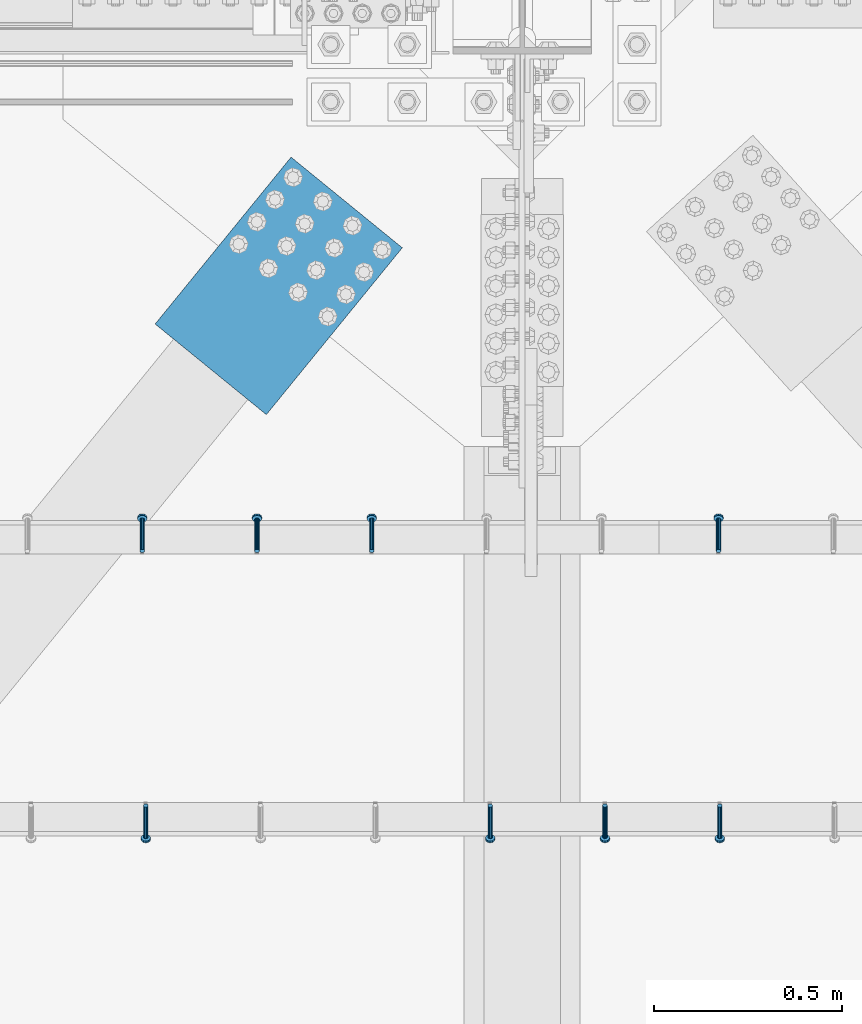
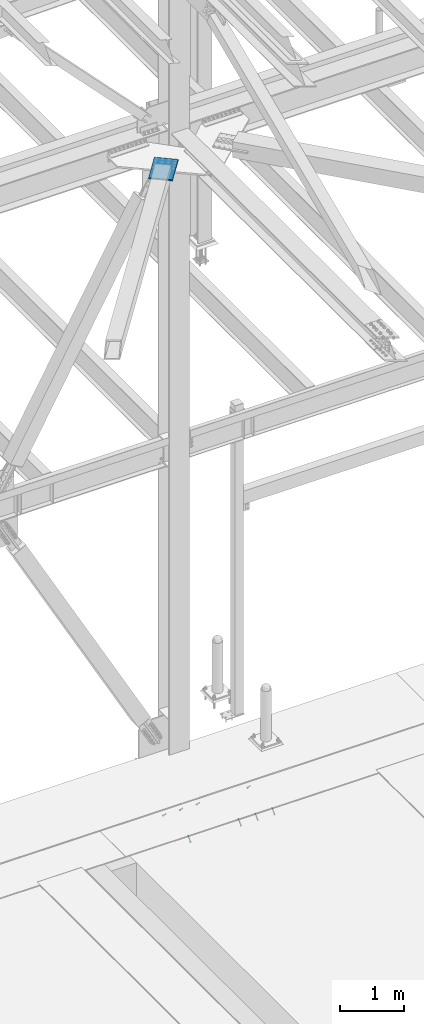
# One storey, part 2531 of 3843: 8 members, 1 beam, 4 elements without a shape of their own.
"""IFC2X3 building model written with IfcOpenShell, lengths in millimetres."""

from ifc_helpers import new_model, si_unit, frame, origin_with_axes, place, context, subcontext, project, spatial, faceted_brep, material, type_object, element, aggregate, save


model = new_model("IFC2X3")

# Units and contexts
model_context = context("Model", 3, precision=1e-05, world=origin_with_axes())
body_context = subcontext(model_context, "Body", "Model", "MODEL_VIEW")
ifc_project = project(units=[si_unit("LENGTHUNIT", "METRE", prefix="MILLI"), si_unit("AREAUNIT", "SQUARE_METRE"), si_unit("VOLUMEUNIT", "CUBIC_METRE"), si_unit("MASSUNIT", "GRAM", prefix="KILO"), si_unit("TIMEUNIT", "SECOND"), si_unit("PLANEANGLEUNIT", "RADIAN"), si_unit("SOLIDANGLEUNIT", "STERADIAN"), si_unit("THERMODYNAMICTEMPERATUREUNIT", "DEGREE_CELSIUS"), si_unit("LUMINOUSINTENSITYUNIT", "LUMEN")], contexts=[model_context])

# Site, building, storey
site_placement = place(None, origin_with_axes())
site = spatial("IfcSite", under=ifc_project, at=site_placement, CompositionType="ELEMENT")
building_placement = place(site_placement, origin_with_axes())
building = spatial("IfcBuilding", under=site, at=building_placement, Name="Undefined", CompositionType="ELEMENT")
storey_placement = place(building_placement, origin_with_axes())
storey = spatial("IfcBuildingStorey", under=building, at=storey_placement, Name="Undefined", CompositionType="ELEMENT", Elevation=0.0)

# Assembly, members
assembly_1_placement = place(storey_placement, origin_with_axes())
assembly_1 = element("IfcElementAssembly", 1, at=assembly_1_placement, inside=storey, Name="EMBED_ANGLE", AssemblyPlace="NOTDEFINED", PredefinedType="RIGID_FRAME")
ifc_material_1 = material(Name="STEEL/A108")
member_type = type_object("IfcMemberType", PredefinedType="NOTDEFINED")
member_1_placement = place(assembly_1_placement, frame((63161.050304107, 90041.2848125, 30446.6625), z_axis=(-1.0, 0.0, 0.0), x_axis=(0.0, -0.707106781186548, -0.707106781186548)))
member_1 = element("IfcMember", 2, at=member_1_placement, type_object=member_type, material=ifc_material_1, Name="HEADED STUD ANCHOR", context=body_context, shape_type="Brep", body=[
    faceted_brep([(7.27595761418343e-12, -3.18000006675175, 5.5), (0.0, -5.49999999998363, 3.1800000667572), (118.110000000976, -5.49999999999091, 3.1800000667572), (118.110000000983, -3.18000006675175, 5.5), (0.0, -6.3499999046162, 0.0), (118.110000000968, -6.34999990461256, 0.0), (0.0, -5.49999999998363, -3.1800000667572), (118.110000000976, -5.49999999999091, -3.1800000667572), (7.27595761418343e-12, -3.18000006675175, -5.5), (118.110000000983, -3.18000006675175, -5.5), (7.27595761418343e-12, -1.81898940354586e-12, -6.34999990463257), (118.110000000968, -1.81898940354586e-12, -6.34999990463257), (0.0, 3.18000006675175, -5.5), (118.110000000968, 3.18000006674811, -5.5), (7.27595761418343e-12, 5.49999999998363, -3.1800000667572), (118.110000000983, 5.49999999998363, -3.1800000667572), (7.27595761418343e-12, 6.3499999046162, 0.0), (118.110000000976, 6.34999990461256, 0.0), (7.27595761418343e-12, 5.49999999998363, 3.1800000667572), (118.110000000983, 5.49999999998363, 3.1800000667572), (0.0, 3.18000006675175, 5.5), (118.110000000968, 3.18000006674811, 5.5), (7.27595761418343e-12, -1.81898940354586e-12, 6.34999990463257), (118.110000000968, -1.81898940354586e-12, 6.34999990463257), (120.650000000991, -10.9899997710909, 6.34999990463257), (120.650000000998, -6.34000015257152, 10.9899997711182), (120.650000000991, -12.6999998092379, 0.0), (120.650000000991, -10.9899997710909, -6.34999990463257), (120.650000000998, -6.34000015257152, -10.9899997711182), (120.650000000991, -1.81898940354586e-12, -12.6899995803833), (120.650000000991, 6.34000015257152, -10.9899997711182), (120.650000000998, 10.9899997710909, -6.34999990463257), (120.650000000991, 12.6999998092342, 0.0), (120.650000000998, 10.9899997710909, 6.34999990463257), (120.650000000991, 6.34000015257152, 10.9899997711182), (120.650000000991, -1.81898940354586e-12, 12.6899995803833), (127.000000001048, -10.9899997710945, 6.34999990463257), (127.000000001048, -6.34000015257152, 10.9899997711182), (127.000000001048, -12.6999998092342, 0.0), (127.000000001048, -10.9899997710945, -6.34999990463257), (127.000000001048, -6.34000015257152, -10.9899997711182), (127.000000001048, 1.81898940354586e-12, -12.6899995803833), (127.000000001048, 6.34000015256788, -10.9899997711182), (127.000000001048, 10.9899997710909, -6.34999990463257), (127.000000001048, 12.6999998092379, 0.0), (127.000000001048, 10.9899997710909, 6.34999990463257), (127.000000001048, 6.34000015256788, 10.9899997711182), (127.000000001048, 1.81898940354586e-12, 12.6899995803833)], [[[0, 1, 2, 3]], [[1, 4, 5, 2]], [[4, 6, 7, 5]], [[6, 8, 9, 7]], [[8, 10, 11, 9]], [[10, 12, 13, 11]], [[12, 14, 15, 13]], [[14, 16, 17, 15]], [[16, 18, 19, 17]], [[18, 20, 21, 19]], [[20, 22, 23, 21]], [[22, 0, 3, 23]], [[22, 20, 18, 16, 14, 12, 10, 8, 6, 4, 1, 0]], [[3, 2, 24, 25]], [[2, 5, 26, 24]], [[5, 7, 27, 26]], [[7, 9, 28, 27]], [[9, 11, 29, 28]], [[11, 13, 30, 29]], [[13, 15, 31, 30]], [[15, 17, 32, 31]], [[17, 19, 33, 32]], [[19, 21, 34, 33]], [[21, 23, 35, 34]], [[23, 3, 25, 35]], [[25, 24, 36, 37]], [[24, 26, 38, 36]], [[26, 27, 39, 38]], [[27, 28, 40, 39]], [[28, 29, 41, 40]], [[29, 30, 42, 41]], [[30, 31, 43, 42]], [[31, 32, 44, 43]], [[32, 33, 45, 44]], [[33, 34, 46, 45]], [[34, 35, 47, 46]], [[35, 25, 37, 47]], [[38, 39, 40, 41, 42, 43, 44, 45, 46, 47, 37, 36]]]),
])
member_2_placement = place(assembly_1_placement, frame((62856.250304107, 90041.2848125, 30446.6625), z_axis=(-1.0, 0.0, 0.0), x_axis=(0.0, -0.707106781186548, -0.707106781186548)))
member_2 = element("IfcMember", 3, at=member_2_placement, type_object=member_type, material=ifc_material_1, Name="HEADED STUD ANCHOR", context=body_context, shape_type="Brep", body=[
    faceted_brep([(7.27595761418343e-12, -3.18000006675175, 5.5), (0.0, -5.49999999998363, 3.1800000667572), (118.110000000976, -5.49999999999091, 3.1800000667572), (118.110000000983, -3.18000006675175, 5.5), (0.0, -6.3499999046162, 0.0), (118.110000000968, -6.34999990461256, 0.0), (0.0, -5.49999999998363, -3.1800000667572), (118.110000000976, -5.49999999999091, -3.1800000667572), (7.27595761418343e-12, -3.18000006675175, -5.5), (118.110000000983, -3.18000006675175, -5.5), (7.27595761418343e-12, -1.81898940354586e-12, -6.34999990463257), (118.110000000968, -1.81898940354586e-12, -6.34999990463257), (0.0, 3.18000006675175, -5.5), (118.110000000968, 3.18000006674811, -5.5), (7.27595761418343e-12, 5.49999999998363, -3.1800000667572), (118.110000000983, 5.49999999998363, -3.1800000667572), (7.27595761418343e-12, 6.3499999046162, 0.0), (118.110000000976, 6.34999990461256, 0.0), (7.27595761418343e-12, 5.49999999998363, 3.1800000667572), (118.110000000983, 5.49999999998363, 3.1800000667572), (0.0, 3.18000006675175, 5.5), (118.110000000968, 3.18000006674811, 5.5), (7.27595761418343e-12, -1.81898940354586e-12, 6.34999990463257), (118.110000000968, -1.81898940354586e-12, 6.34999990463257), (120.650000000991, -10.9899997710909, 6.34999990463257), (120.650000000998, -6.34000015257152, 10.9899997711182), (120.650000000991, -12.6999998092379, 0.0), (120.650000000991, -10.9899997710909, -6.34999990463257), (120.650000000998, -6.34000015257152, -10.9899997711182), (120.650000000991, -1.81898940354586e-12, -12.6899995803833), (120.650000000991, 6.34000015257152, -10.9899997711182), (120.650000000998, 10.9899997710909, -6.34999990463257), (120.650000000991, 12.6999998092342, 0.0), (120.650000000998, 10.9899997710909, 6.34999990463257), (120.650000000991, 6.34000015257152, 10.9899997711182), (120.650000000991, -1.81898940354586e-12, 12.6899995803833), (127.000000001048, -10.9899997710945, 6.34999990463257), (127.000000001048, -6.34000015257152, 10.9899997711182), (127.000000001048, -12.6999998092342, 0.0), (127.000000001048, -10.9899997710945, -6.34999990463257), (127.000000001048, -6.34000015257152, -10.9899997711182), (127.000000001048, 1.81898940354586e-12, -12.6899995803833), (127.000000001048, 6.34000015256788, -10.9899997711182), (127.000000001048, 10.9899997710909, -6.34999990463257), (127.000000001048, 12.6999998092379, 0.0), (127.000000001048, 10.9899997710909, 6.34999990463257), (127.000000001048, 6.34000015256788, 10.9899997711182), (127.000000001048, 1.81898940354586e-12, 12.6899995803833)], [[[0, 1, 2, 3]], [[1, 4, 5, 2]], [[4, 6, 7, 5]], [[6, 8, 9, 7]], [[8, 10, 11, 9]], [[10, 12, 13, 11]], [[12, 14, 15, 13]], [[14, 16, 17, 15]], [[16, 18, 19, 17]], [[18, 20, 21, 19]], [[20, 22, 23, 21]], [[22, 0, 3, 23]], [[22, 20, 18, 16, 14, 12, 10, 8, 6, 4, 1, 0]], [[3, 2, 24, 25]], [[2, 5, 26, 24]], [[5, 7, 27, 26]], [[7, 9, 28, 27]], [[9, 11, 29, 28]], [[11, 13, 30, 29]], [[13, 15, 31, 30]], [[15, 17, 32, 31]], [[17, 19, 33, 32]], [[19, 21, 34, 33]], [[21, 23, 35, 34]], [[23, 3, 25, 35]], [[25, 24, 36, 37]], [[24, 26, 38, 36]], [[26, 27, 39, 38]], [[27, 28, 40, 39]], [[28, 29, 41, 40]], [[29, 30, 42, 41]], [[30, 31, 43, 42]], [[31, 32, 44, 43]], [[32, 33, 45, 44]], [[33, 34, 46, 45]], [[34, 35, 47, 46]], [[35, 25, 37, 47]], [[38, 39, 40, 41, 42, 43, 44, 45, 46, 47, 37, 36]]]),
])
member_3_placement = place(assembly_1_placement, frame((62551.450304107, 90041.2848125, 30446.6625), z_axis=(-1.0, 0.0, 0.0), x_axis=(0.0, -0.707106781186548, -0.707106781186548)))
member_3 = element("IfcMember", 4, at=member_3_placement, type_object=member_type, material=ifc_material_1, Name="HEADED STUD ANCHOR", context=body_context, shape_type="Brep", body=[
    faceted_brep([(7.27595761418343e-12, -3.18000006675175, 5.5), (0.0, -5.49999999998363, 3.1800000667572), (118.110000000976, -5.49999999999091, 3.1800000667572), (118.110000000983, -3.18000006675175, 5.5), (0.0, -6.3499999046162, 0.0), (118.110000000968, -6.34999990461256, 0.0), (0.0, -5.49999999998363, -3.1800000667572), (118.110000000976, -5.49999999999091, -3.1800000667572), (7.27595761418343e-12, -3.18000006675175, -5.5), (118.110000000983, -3.18000006675175, -5.5), (7.27595761418343e-12, -1.81898940354586e-12, -6.34999990463257), (118.110000000968, -1.81898940354586e-12, -6.34999990463257), (0.0, 3.18000006675175, -5.5), (118.110000000968, 3.18000006674811, -5.5), (7.27595761418343e-12, 5.49999999998363, -3.1800000667572), (118.110000000983, 5.49999999998363, -3.1800000667572), (7.27595761418343e-12, 6.3499999046162, 0.0), (118.110000000976, 6.34999990461256, 0.0), (7.27595761418343e-12, 5.49999999998363, 3.1800000667572), (118.110000000983, 5.49999999998363, 3.1800000667572), (0.0, 3.18000006675175, 5.5), (118.110000000968, 3.18000006674811, 5.5), (7.27595761418343e-12, -1.81898940354586e-12, 6.34999990463257), (118.110000000968, -1.81898940354586e-12, 6.34999990463257), (120.650000000991, -10.9899997710909, 6.34999990463257), (120.650000000998, -6.34000015257152, 10.9899997711182), (120.650000000991, -12.6999998092379, 0.0), (120.650000000991, -10.9899997710909, -6.34999990463257), (120.650000000998, -6.34000015257152, -10.9899997711182), (120.650000000991, -1.81898940354586e-12, -12.6899995803833), (120.650000000991, 6.34000015257152, -10.9899997711182), (120.650000000998, 10.9899997710909, -6.34999990463257), (120.650000000991, 12.6999998092342, 0.0), (120.650000000998, 10.9899997710909, 6.34999990463257), (120.650000000991, 6.34000015257152, 10.9899997711182), (120.650000000991, -1.81898940354586e-12, 12.6899995803833), (127.000000001048, -10.9899997710945, 6.34999990463257), (127.000000001048, -6.34000015257152, 10.9899997711182), (127.000000001048, -12.6999998092342, 0.0), (127.000000001048, -10.9899997710945, -6.34999990463257), (127.000000001048, -6.34000015257152, -10.9899997711182), (127.000000001048, 1.81898940354586e-12, -12.6899995803833), (127.000000001048, 6.34000015256788, -10.9899997711182), (127.000000001048, 10.9899997710909, -6.34999990463257), (127.000000001048, 12.6999998092379, 0.0), (127.000000001048, 10.9899997710909, 6.34999990463257), (127.000000001048, 6.34000015256788, 10.9899997711182), (127.000000001048, 1.81898940354586e-12, 12.6899995803833)], [[[0, 1, 2, 3]], [[1, 4, 5, 2]], [[4, 6, 7, 5]], [[6, 8, 9, 7]], [[8, 10, 11, 9]], [[10, 12, 13, 11]], [[12, 14, 15, 13]], [[14, 16, 17, 15]], [[16, 18, 19, 17]], [[18, 20, 21, 19]], [[20, 22, 23, 21]], [[22, 0, 3, 23]], [[22, 20, 18, 16, 14, 12, 10, 8, 6, 4, 1, 0]], [[3, 2, 24, 25]], [[2, 5, 26, 24]], [[5, 7, 27, 26]], [[7, 9, 28, 27]], [[9, 11, 29, 28]], [[11, 13, 30, 29]], [[13, 15, 31, 30]], [[15, 17, 32, 31]], [[17, 19, 33, 32]], [[19, 21, 34, 33]], [[21, 23, 35, 34]], [[23, 3, 25, 35]], [[25, 24, 36, 37]], [[24, 26, 38, 36]], [[26, 27, 39, 38]], [[27, 28, 40, 39]], [[28, 29, 41, 40]], [[29, 30, 42, 41]], [[30, 31, 43, 42]], [[31, 32, 44, 43]], [[32, 33, 45, 44]], [[33, 34, 46, 45]], [[34, 35, 47, 46]], [[35, 25, 37, 47]], [[38, 39, 40, 41, 42, 43, 44, 45, 46, 47, 37, 36]]]),
])
member_4_placement = place(assembly_1_placement, frame((61637.050304107, 90041.2848125, 30446.6625), z_axis=(-1.0, 0.0, 0.0), x_axis=(0.0, -0.707106781186548, -0.707106781186548)))
member_4 = element("IfcMember", 5, at=member_4_placement, type_object=member_type, material=ifc_material_1, Name="HEADED STUD ANCHOR", context=body_context, shape_type="Brep", body=[
    faceted_brep([(7.27595761418343e-12, -3.18000006675175, 5.5), (0.0, -5.49999999998363, 3.1800000667572), (118.110000000976, -5.49999999999091, 3.1800000667572), (118.110000000983, -3.18000006675175, 5.5), (0.0, -6.3499999046162, 0.0), (118.110000000968, -6.34999990461256, 0.0), (0.0, -5.49999999998363, -3.1800000667572), (118.110000000976, -5.49999999999091, -3.1800000667572), (7.27595761418343e-12, -3.18000006675175, -5.5), (118.110000000983, -3.18000006675175, -5.5), (7.27595761418343e-12, -1.81898940354586e-12, -6.34999990463257), (118.110000000968, -1.81898940354586e-12, -6.34999990463257), (0.0, 3.18000006675175, -5.5), (118.110000000968, 3.18000006674811, -5.5), (7.27595761418343e-12, 5.49999999998363, -3.1800000667572), (118.110000000983, 5.49999999998363, -3.1800000667572), (7.27595761418343e-12, 6.3499999046162, 0.0), (118.110000000976, 6.34999990461256, 0.0), (7.27595761418343e-12, 5.49999999998363, 3.1800000667572), (118.110000000983, 5.49999999998363, 3.1800000667572), (0.0, 3.18000006675175, 5.5), (118.110000000968, 3.18000006674811, 5.5), (7.27595761418343e-12, -1.81898940354586e-12, 6.34999990463257), (118.110000000968, -1.81898940354586e-12, 6.34999990463257), (120.650000000991, -10.9899997710909, 6.34999990463257), (120.650000000998, -6.34000015257152, 10.9899997711182), (120.650000000991, -12.6999998092379, 0.0), (120.650000000991, -10.9899997710909, -6.34999990463257), (120.650000000998, -6.34000015257152, -10.9899997711182), (120.650000000991, -1.81898940354586e-12, -12.6899995803833), (120.650000000991, 6.34000015257152, -10.9899997711182), (120.650000000998, 10.9899997710909, -6.34999990463257), (120.650000000991, 12.6999998092342, 0.0), (120.650000000998, 10.9899997710909, 6.34999990463257), (120.650000000991, 6.34000015257152, 10.9899997711182), (120.650000000991, -1.81898940354586e-12, 12.6899995803833), (127.000000001048, -10.9899997710945, 6.34999990463257), (127.000000001048, -6.34000015257152, 10.9899997711182), (127.000000001048, -12.6999998092342, 0.0), (127.000000001048, -10.9899997710945, -6.34999990463257), (127.000000001048, -6.34000015257152, -10.9899997711182), (127.000000001048, 1.81898940354586e-12, -12.6899995803833), (127.000000001048, 6.34000015256788, -10.9899997711182), (127.000000001048, 10.9899997710909, -6.34999990463257), (127.000000001048, 12.6999998092379, 0.0), (127.000000001048, 10.9899997710909, 6.34999990463257), (127.000000001048, 6.34000015256788, 10.9899997711182), (127.000000001048, 1.81898940354586e-12, 12.6899995803833)], [[[0, 1, 2, 3]], [[1, 4, 5, 2]], [[4, 6, 7, 5]], [[6, 8, 9, 7]], [[8, 10, 11, 9]], [[10, 12, 13, 11]], [[12, 14, 15, 13]], [[14, 16, 17, 15]], [[16, 18, 19, 17]], [[18, 20, 21, 19]], [[20, 22, 23, 21]], [[22, 0, 3, 23]], [[22, 20, 18, 16, 14, 12, 10, 8, 6, 4, 1, 0]], [[3, 2, 24, 25]], [[2, 5, 26, 24]], [[5, 7, 27, 26]], [[7, 9, 28, 27]], [[9, 11, 29, 28]], [[11, 13, 30, 29]], [[13, 15, 31, 30]], [[15, 17, 32, 31]], [[17, 19, 33, 32]], [[19, 21, 34, 33]], [[21, 23, 35, 34]], [[23, 3, 25, 35]], [[25, 24, 36, 37]], [[24, 26, 38, 36]], [[26, 27, 39, 38]], [[27, 28, 40, 39]], [[28, 29, 41, 40]], [[29, 30, 42, 41]], [[30, 31, 43, 42]], [[31, 32, 44, 43]], [[32, 33, 45, 44]], [[33, 34, 46, 45]], [[34, 35, 47, 46]], [[35, 25, 37, 47]], [[38, 39, 40, 41, 42, 43, 44, 45, 46, 47, 37, 36]]]),
])
aggregate(assembly_1, [member_1, member_2, member_3, member_4])

# Assembly, member
assembly_2_placement = place(storey_placement, origin_with_axes())
assembly_2 = element("IfcElementAssembly", 6, at=assembly_2_placement, inside=storey, Name="EMBED_ANGLE", AssemblyPlace="NOTDEFINED", PredefinedType="RIGID_FRAME")
member_5_placement = place(assembly_2_placement, frame((63157.8621552734, 90717.5605224609, 30446.6625), z_axis=(-1.0, 0.0, 0.0), x_axis=(5.70000238222118e-08, 0.707106781186546, -0.707106781186546)))
member_5 = element("IfcMember", 7, at=member_5_placement, type_object=member_type, material=ifc_material_1, Name="HEADED STUD ANCHOR", context=body_context, shape_type="Brep", body=[
    faceted_brep([(7.27595761418343e-12, -3.18000006675175, 5.5), (0.0, -5.49999999998363, 3.1800000667572), (118.110000000976, -5.49999999999091, 3.1800000667572), (118.110000000983, -3.18000006675175, 5.5), (0.0, -6.3499999046162, 0.0), (118.110000000968, -6.34999990461256, 0.0), (0.0, -5.49999999998363, -3.1800000667572), (118.110000000976, -5.49999999999091, -3.1800000667572), (7.27595761418343e-12, -3.18000006675175, -5.5), (118.110000000983, -3.18000006675175, -5.5), (7.27595761418343e-12, -1.81898940354586e-12, -6.34999990463257), (118.110000000968, -1.81898940354586e-12, -6.34999990463257), (0.0, 3.18000006675175, -5.5), (118.110000000968, 3.18000006674811, -5.5), (7.27595761418343e-12, 5.49999999998363, -3.1800000667572), (118.110000000983, 5.49999999998363, -3.1800000667572), (7.27595761418343e-12, 6.3499999046162, 0.0), (118.110000000976, 6.34999990461256, 0.0), (7.27595761418343e-12, 5.49999999998363, 3.1800000667572), (118.110000000983, 5.49999999998363, 3.1800000667572), (0.0, 3.18000006675175, 5.5), (118.110000000968, 3.18000006674811, 5.5), (7.27595761418343e-12, -1.81898940354586e-12, 6.34999990463257), (118.110000000968, -1.81898940354586e-12, 6.34999990463257), (120.650000000991, -10.9899997710909, 6.34999990463257), (120.650000000998, -6.34000015257152, 10.9899997711182), (120.650000000991, -12.6999998092379, 0.0), (120.650000000991, -10.9899997710909, -6.34999990463257), (120.650000000998, -6.34000015257152, -10.9899997711182), (120.650000000991, -1.81898940354586e-12, -12.6899995803833), (120.650000000991, 6.34000015257152, -10.9899997711182), (120.650000000998, 10.9899997710909, -6.34999990463257), (120.650000000991, 12.6999998092342, 0.0), (120.650000000998, 10.9899997710909, 6.34999990463257), (120.650000000991, 6.34000015257152, 10.9899997711182), (120.650000000991, -1.81898940354586e-12, 12.6899995803833), (127.000000001048, -10.9899997710945, 6.34999990463257), (127.000000001048, -6.34000015257152, 10.9899997711182), (127.000000001048, -12.6999998092342, 0.0), (127.000000001048, -10.9899997710945, -6.34999990463257), (127.000000001048, -6.34000015257152, -10.9899997711182), (127.000000001048, 1.81898940354586e-12, -12.6899995803833), (127.000000001048, 6.34000015256788, -10.9899997711182), (127.000000001048, 10.9899997710909, -6.34999990463257), (127.000000001048, 12.6999998092379, 0.0), (127.000000001048, 10.9899997710909, 6.34999990463257), (127.000000001048, 6.34000015256788, 10.9899997711182), (127.000000001048, 1.81898940354586e-12, 12.6899995803833)], [[[0, 1, 2, 3]], [[1, 4, 5, 2]], [[4, 6, 7, 5]], [[6, 8, 9, 7]], [[8, 10, 11, 9]], [[10, 12, 13, 11]], [[12, 14, 15, 13]], [[14, 16, 17, 15]], [[16, 18, 19, 17]], [[18, 20, 21, 19]], [[20, 22, 23, 21]], [[22, 0, 3, 23]], [[22, 20, 18, 16, 14, 12, 10, 8, 6, 4, 1, 0]], [[3, 2, 24, 25]], [[2, 5, 26, 24]], [[5, 7, 27, 26]], [[7, 9, 28, 27]], [[9, 11, 29, 28]], [[11, 13, 30, 29]], [[13, 15, 31, 30]], [[15, 17, 32, 31]], [[17, 19, 33, 32]], [[19, 21, 34, 33]], [[21, 23, 35, 34]], [[23, 3, 25, 35]], [[25, 24, 36, 37]], [[24, 26, 38, 36]], [[26, 27, 39, 38]], [[27, 28, 40, 39]], [[28, 29, 41, 40]], [[29, 30, 42, 41]], [[30, 31, 43, 42]], [[31, 32, 44, 43]], [[32, 33, 45, 44]], [[33, 34, 46, 45]], [[34, 35, 47, 46]], [[35, 25, 37, 47]], [[38, 39, 40, 41, 42, 43, 44, 45, 46, 47, 37, 36]]]),
])
aggregate(assembly_2, [member_5])

# Assembly, members
assembly_3_placement = place(storey_placement, origin_with_axes())
assembly_3 = element("IfcElementAssembly", 8, at=assembly_3_placement, inside=storey, Name="EMBED_ANGLE", AssemblyPlace="NOTDEFINED", PredefinedType="RIGID_FRAME")
member_6_placement = place(assembly_3_placement, frame((62237.1121552734, 90717.5605224609, 30446.6625), z_axis=(-1.0, 0.0, 0.0), x_axis=(5.70000238222118e-08, 0.707106781186546, -0.707106781186546)))
member_6 = element("IfcMember", 9, at=member_6_placement, type_object=member_type, material=ifc_material_1, Name="HEADED STUD ANCHOR", context=body_context, shape_type="Brep", body=[
    faceted_brep([(7.27595761418343e-12, -3.18000006675175, 5.5), (0.0, -5.49999999998363, 3.1800000667572), (118.110000000976, -5.49999999999091, 3.1800000667572), (118.110000000983, -3.18000006675175, 5.5), (0.0, -6.3499999046162, 0.0), (118.110000000968, -6.34999990461256, 0.0), (0.0, -5.49999999998363, -3.1800000667572), (118.110000000976, -5.49999999999091, -3.1800000667572), (7.27595761418343e-12, -3.18000006675175, -5.5), (118.110000000983, -3.18000006675175, -5.5), (7.27595761418343e-12, -1.81898940354586e-12, -6.34999990463257), (118.110000000968, -1.81898940354586e-12, -6.34999990463257), (0.0, 3.18000006675175, -5.5), (118.110000000968, 3.18000006674811, -5.5), (7.27595761418343e-12, 5.49999999998363, -3.1800000667572), (118.110000000983, 5.49999999998363, -3.1800000667572), (7.27595761418343e-12, 6.3499999046162, 0.0), (118.110000000976, 6.34999990461256, 0.0), (7.27595761418343e-12, 5.49999999998363, 3.1800000667572), (118.110000000983, 5.49999999998363, 3.1800000667572), (0.0, 3.18000006675175, 5.5), (118.110000000968, 3.18000006674811, 5.5), (7.27595761418343e-12, -1.81898940354586e-12, 6.34999990463257), (118.110000000968, -1.81898940354586e-12, 6.34999990463257), (120.650000000991, -10.9899997710909, 6.34999990463257), (120.650000000998, -6.34000015257152, 10.9899997711182), (120.650000000991, -12.6999998092379, 0.0), (120.650000000991, -10.9899997710909, -6.34999990463257), (120.650000000998, -6.34000015257152, -10.9899997711182), (120.650000000991, -1.81898940354586e-12, -12.6899995803833), (120.650000000991, 6.34000015257152, -10.9899997711182), (120.650000000998, 10.9899997710909, -6.34999990463257), (120.650000000991, 12.6999998092342, 0.0), (120.650000000998, 10.9899997710909, 6.34999990463257), (120.650000000991, 6.34000015257152, 10.9899997711182), (120.650000000991, -1.81898940354586e-12, 12.6899995803833), (127.000000001048, -10.9899997710945, 6.34999990463257), (127.000000001048, -6.34000015257152, 10.9899997711182), (127.000000001048, -12.6999998092342, 0.0), (127.000000001048, -10.9899997710945, -6.34999990463257), (127.000000001048, -6.34000015257152, -10.9899997711182), (127.000000001048, 1.81898940354586e-12, -12.6899995803833), (127.000000001048, 6.34000015256788, -10.9899997711182), (127.000000001048, 10.9899997710909, -6.34999990463257), (127.000000001048, 12.6999998092379, 0.0), (127.000000001048, 10.9899997710909, 6.34999990463257), (127.000000001048, 6.34000015256788, 10.9899997711182), (127.000000001048, 1.81898940354586e-12, 12.6899995803833)], [[[0, 1, 2, 3]], [[1, 4, 5, 2]], [[4, 6, 7, 5]], [[6, 8, 9, 7]], [[8, 10, 11, 9]], [[10, 12, 13, 11]], [[12, 14, 15, 13]], [[14, 16, 17, 15]], [[16, 18, 19, 17]], [[18, 20, 21, 19]], [[20, 22, 23, 21]], [[22, 0, 3, 23]], [[22, 20, 18, 16, 14, 12, 10, 8, 6, 4, 1, 0]], [[3, 2, 24, 25]], [[2, 5, 26, 24]], [[5, 7, 27, 26]], [[7, 9, 28, 27]], [[9, 11, 29, 28]], [[11, 13, 30, 29]], [[13, 15, 31, 30]], [[15, 17, 32, 31]], [[17, 19, 33, 32]], [[19, 21, 34, 33]], [[21, 23, 35, 34]], [[23, 3, 25, 35]], [[25, 24, 36, 37]], [[24, 26, 38, 36]], [[26, 27, 39, 38]], [[27, 28, 40, 39]], [[28, 29, 41, 40]], [[29, 30, 42, 41]], [[30, 31, 43, 42]], [[31, 32, 44, 43]], [[32, 33, 45, 44]], [[33, 34, 46, 45]], [[34, 35, 47, 46]], [[35, 25, 37, 47]], [[38, 39, 40, 41, 42, 43, 44, 45, 46, 47, 37, 36]]]),
])
member_7_placement = place(assembly_3_placement, frame((61932.3121552734, 90717.5605224609, 30446.6625), z_axis=(-1.0, 0.0, 0.0), x_axis=(5.70000238222118e-08, 0.707106781186546, -0.707106781186546)))
member_7 = element("IfcMember", 10, at=member_7_placement, type_object=member_type, material=ifc_material_1, Name="HEADED STUD ANCHOR", context=body_context, shape_type="Brep", body=[
    faceted_brep([(7.27595761418343e-12, -3.18000006675175, 5.5), (0.0, -5.49999999998363, 3.1800000667572), (118.110000000976, -5.49999999999091, 3.1800000667572), (118.110000000983, -3.18000006675175, 5.5), (0.0, -6.3499999046162, 0.0), (118.110000000968, -6.34999990461256, 0.0), (0.0, -5.49999999998363, -3.1800000667572), (118.110000000976, -5.49999999999091, -3.1800000667572), (7.27595761418343e-12, -3.18000006675175, -5.5), (118.110000000983, -3.18000006675175, -5.5), (7.27595761418343e-12, -1.81898940354586e-12, -6.34999990463257), (118.110000000968, -1.81898940354586e-12, -6.34999990463257), (0.0, 3.18000006675175, -5.5), (118.110000000968, 3.18000006674811, -5.5), (7.27595761418343e-12, 5.49999999998363, -3.1800000667572), (118.110000000983, 5.49999999998363, -3.1800000667572), (7.27595761418343e-12, 6.3499999046162, 0.0), (118.110000000976, 6.34999990461256, 0.0), (7.27595761418343e-12, 5.49999999998363, 3.1800000667572), (118.110000000983, 5.49999999998363, 3.1800000667572), (0.0, 3.18000006675175, 5.5), (118.110000000968, 3.18000006674811, 5.5), (7.27595761418343e-12, -1.81898940354586e-12, 6.34999990463257), (118.110000000968, -1.81898940354586e-12, 6.34999990463257), (120.650000000991, -10.9899997710909, 6.34999990463257), (120.650000000998, -6.34000015257152, 10.9899997711182), (120.650000000991, -12.6999998092379, 0.0), (120.650000000991, -10.9899997710909, -6.34999990463257), (120.650000000998, -6.34000015257152, -10.9899997711182), (120.650000000991, -1.81898940354586e-12, -12.6899995803833), (120.650000000991, 6.34000015257152, -10.9899997711182), (120.650000000998, 10.9899997710909, -6.34999990463257), (120.650000000991, 12.6999998092342, 0.0), (120.650000000998, 10.9899997710909, 6.34999990463257), (120.650000000991, 6.34000015257152, 10.9899997711182), (120.650000000991, -1.81898940354586e-12, 12.6899995803833), (127.000000001048, -10.9899997710945, 6.34999990463257), (127.000000001048, -6.34000015257152, 10.9899997711182), (127.000000001048, -12.6999998092342, 0.0), (127.000000001048, -10.9899997710945, -6.34999990463257), (127.000000001048, -6.34000015257152, -10.9899997711182), (127.000000001048, 1.81898940354586e-12, -12.6899995803833), (127.000000001048, 6.34000015256788, -10.9899997711182), (127.000000001048, 10.9899997710909, -6.34999990463257), (127.000000001048, 12.6999998092379, 0.0), (127.000000001048, 10.9899997710909, 6.34999990463257), (127.000000001048, 6.34000015256788, 10.9899997711182), (127.000000001048, 1.81898940354586e-12, 12.6899995803833)], [[[0, 1, 2, 3]], [[1, 4, 5, 2]], [[4, 6, 7, 5]], [[6, 8, 9, 7]], [[8, 10, 11, 9]], [[10, 12, 13, 11]], [[12, 14, 15, 13]], [[14, 16, 17, 15]], [[16, 18, 19, 17]], [[18, 20, 21, 19]], [[20, 22, 23, 21]], [[22, 0, 3, 23]], [[22, 20, 18, 16, 14, 12, 10, 8, 6, 4, 1, 0]], [[3, 2, 24, 25]], [[2, 5, 26, 24]], [[5, 7, 27, 26]], [[7, 9, 28, 27]], [[9, 11, 29, 28]], [[11, 13, 30, 29]], [[13, 15, 31, 30]], [[15, 17, 32, 31]], [[17, 19, 33, 32]], [[19, 21, 34, 33]], [[21, 23, 35, 34]], [[23, 3, 25, 35]], [[25, 24, 36, 37]], [[24, 26, 38, 36]], [[26, 27, 39, 38]], [[27, 28, 40, 39]], [[28, 29, 41, 40]], [[29, 30, 42, 41]], [[30, 31, 43, 42]], [[31, 32, 44, 43]], [[32, 33, 45, 44]], [[33, 34, 46, 45]], [[34, 35, 47, 46]], [[35, 25, 37, 47]], [[38, 39, 40, 41, 42, 43, 44, 45, 46, 47, 37, 36]]]),
])
member_8_placement = place(assembly_3_placement, frame((61627.5121552734, 90717.5605224609, 30446.6625), z_axis=(-1.0, 0.0, 0.0), x_axis=(5.70000238222118e-08, 0.707106781186546, -0.707106781186546)))
member_8 = element("IfcMember", 11, at=member_8_placement, type_object=member_type, material=ifc_material_1, Name="HEADED STUD ANCHOR", context=body_context, shape_type="Brep", body=[
    faceted_brep([(7.27595761418343e-12, -3.18000006675175, 5.5), (0.0, -5.49999999998363, 3.1800000667572), (118.110000000976, -5.49999999999091, 3.1800000667572), (118.110000000983, -3.18000006675175, 5.5), (0.0, -6.3499999046162, 0.0), (118.110000000968, -6.34999990461256, 0.0), (0.0, -5.49999999998363, -3.1800000667572), (118.110000000976, -5.49999999999091, -3.1800000667572), (7.27595761418343e-12, -3.18000006675175, -5.5), (118.110000000983, -3.18000006675175, -5.5), (7.27595761418343e-12, -1.81898940354586e-12, -6.34999990463257), (118.110000000968, -1.81898940354586e-12, -6.34999990463257), (0.0, 3.18000006675175, -5.5), (118.110000000968, 3.18000006674811, -5.5), (7.27595761418343e-12, 5.49999999998363, -3.1800000667572), (118.110000000983, 5.49999999998363, -3.1800000667572), (7.27595761418343e-12, 6.3499999046162, 0.0), (118.110000000976, 6.34999990461256, 0.0), (7.27595761418343e-12, 5.49999999998363, 3.1800000667572), (118.110000000983, 5.49999999998363, 3.1800000667572), (0.0, 3.18000006675175, 5.5), (118.110000000968, 3.18000006674811, 5.5), (7.27595761418343e-12, -1.81898940354586e-12, 6.34999990463257), (118.110000000968, -1.81898940354586e-12, 6.34999990463257), (120.650000000991, -10.9899997710909, 6.34999990463257), (120.650000000998, -6.34000015257152, 10.9899997711182), (120.650000000991, -12.6999998092379, 0.0), (120.650000000991, -10.9899997710909, -6.34999990463257), (120.650000000998, -6.34000015257152, -10.9899997711182), (120.650000000991, -1.81898940354586e-12, -12.6899995803833), (120.650000000991, 6.34000015257152, -10.9899997711182), (120.650000000998, 10.9899997710909, -6.34999990463257), (120.650000000991, 12.6999998092342, 0.0), (120.650000000998, 10.9899997710909, 6.34999990463257), (120.650000000991, 6.34000015257152, 10.9899997711182), (120.650000000991, -1.81898940354586e-12, 12.6899995803833), (127.000000001048, -10.9899997710945, 6.34999990463257), (127.000000001048, -6.34000015257152, 10.9899997711182), (127.000000001048, -12.6999998092342, 0.0), (127.000000001048, -10.9899997710945, -6.34999990463257), (127.000000001048, -6.34000015257152, -10.9899997711182), (127.000000001048, 1.81898940354586e-12, -12.6899995803833), (127.000000001048, 6.34000015256788, -10.9899997711182), (127.000000001048, 10.9899997710909, -6.34999990463257), (127.000000001048, 12.6999998092379, 0.0), (127.000000001048, 10.9899997710909, 6.34999990463257), (127.000000001048, 6.34000015256788, 10.9899997711182), (127.000000001048, 1.81898940354586e-12, 12.6899995803833)], [[[0, 1, 2, 3]], [[1, 4, 5, 2]], [[4, 6, 7, 5]], [[6, 8, 9, 7]], [[8, 10, 11, 9]], [[10, 12, 13, 11]], [[12, 14, 15, 13]], [[14, 16, 17, 15]], [[16, 18, 19, 17]], [[18, 20, 21, 19]], [[20, 22, 23, 21]], [[22, 0, 3, 23]], [[22, 20, 18, 16, 14, 12, 10, 8, 6, 4, 1, 0]], [[3, 2, 24, 25]], [[2, 5, 26, 24]], [[5, 7, 27, 26]], [[7, 9, 28, 27]], [[9, 11, 29, 28]], [[11, 13, 30, 29]], [[13, 15, 31, 30]], [[15, 17, 32, 31]], [[17, 19, 33, 32]], [[19, 21, 34, 33]], [[21, 23, 35, 34]], [[23, 3, 25, 35]], [[25, 24, 36, 37]], [[24, 26, 38, 36]], [[26, 27, 39, 38]], [[27, 28, 40, 39]], [[28, 29, 41, 40]], [[29, 30, 42, 41]], [[30, 31, 43, 42]], [[31, 32, 44, 43]], [[32, 33, 45, 44]], [[33, 34, 46, 45]], [[34, 35, 47, 46]], [[35, 25, 37, 47]], [[38, 39, 40, 41, 42, 43, 44, 45, 46, 47, 37, 36]]]),
])
aggregate(assembly_3, [member_6, member_7, member_8])

# Assembly, beam
assembly_4_placement = place(storey_placement, origin_with_axes())
assembly_4 = element("IfcElementAssembly", 12, at=assembly_4_placement, inside=storey, AssemblyPlace="NOTDEFINED", PredefinedType="RIGID_FRAME")
ifc_material_2 = material(Name="STEEL/A572-50")
beam_type = type_object("IfcBeamType", PredefinedType="NOTDEFINED")
beam_placement = place(assembly_4_placement, frame((62170.4551400413, 91642.8585876965, 42259.25), z_axis=(-0.775234985789338, 0.631672950828357, 0.0), x_axis=(-0.631672950828363, -0.775234985789334, 0.0)))
beam = element("IfcBeam", 13, at=beam_placement, type_object=beam_type, material=ifc_material_2, Name="PLATE", context=body_context, shape_type="Brep", body=[
    faceted_brep([(5.85714587941766e-10, 12.6999999999971, -190.500000000349), (-6.14818418398499e-10, 12.6999999999971, 190.500000000364), (571.499999996191, 12.6999999999971, 190.49999999936), (571.499999997392, 12.6999999999971, -190.500000001353), (-6.14818418398499e-10, -12.6999999999971, 190.500000000364), (571.499999996191, -12.6999999999971, 190.49999999936), (5.85714587941766e-10, -12.6999999999971, -190.500000000349), (571.499999997392, -12.6999999999971, -190.500000001353)], [[[0, 1, 2, 3]], [[1, 4, 5, 2]], [[4, 6, 7, 5]], [[6, 0, 3, 7]], [[5, 7, 3, 2]], [[6, 4, 1, 0]]]),
])
aggregate(assembly_4, [beam])

save(model, "model.ifc")
